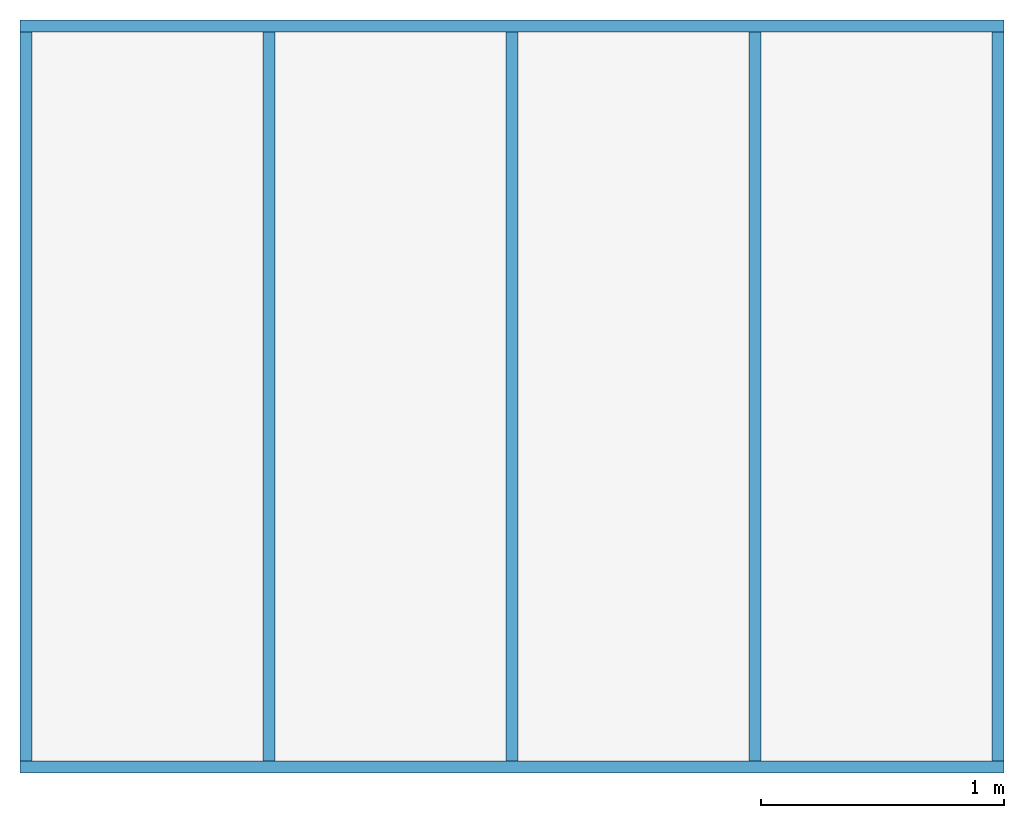
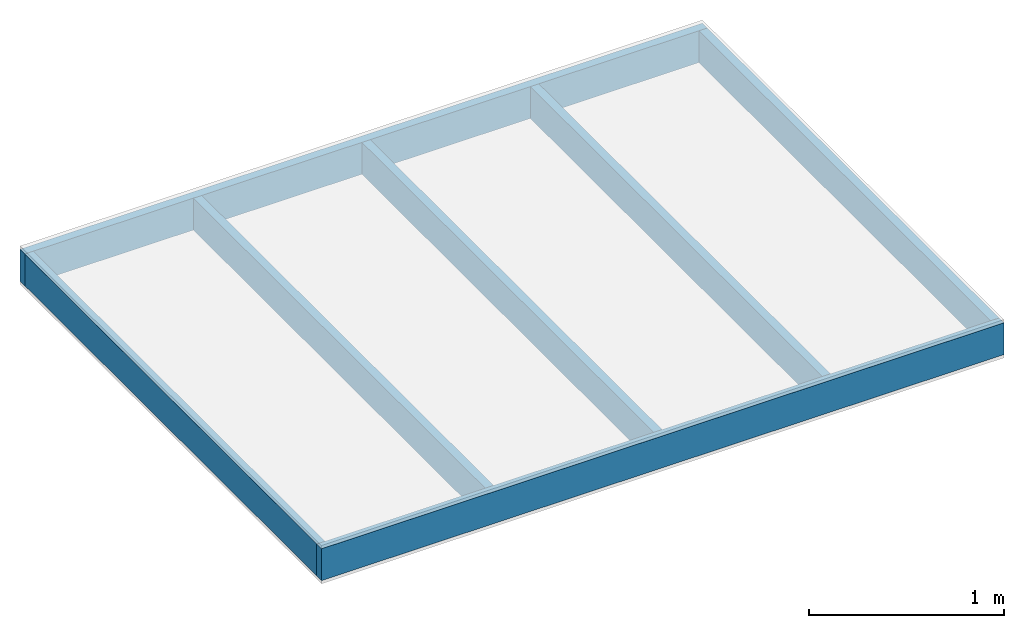
# One storey, part 1 of 2: 6 members, 1 beam.
"""IFC4 building model written with IfcOpenShell, lengths in millimetres."""

from ifc_helpers import new_model, si_unit, frame, origin_with_axes, origin_2d_with_axis, place, context, subcontext, project, spatial, rectangle, extrude, element, save


model = new_model("IFC4")

# Units and contexts
model_context_1 = context("Model", 3, precision=1e-05, world=origin_with_axes())
model_context_2 = context("Model", 3, precision=1e-05, world=origin_with_axes())
plan_context = context("Plan", 2, precision=1e-05, world=origin_2d_with_axis())
body_context = subcontext(model_context_2, "Body", "Model", "MODEL_VIEW")
ifc_project = project(units=[si_unit("AREAUNIT", "SQUARE_METRE"), si_unit("VOLUMEUNIT", "CUBIC_METRE"), si_unit("LENGTHUNIT", "METRE", prefix="MILLI")], contexts=[model_context_1, model_context_2, plan_context])

# Site, building, storey
site = spatial("IfcSite", under=ifc_project)
building = spatial("IfcBuilding", under=site, Name="Building A")
storey = spatial("IfcBuildingStorey", under=building, Name="Ground Floor")

# Members
for number, where, z_axis, x_axis, name in (
    (1, (0.0, 25.0, 0.0), (0.0, 1.0, 0.0), (1.0, 1.0, 0.0), "my_beam"),
    (2, (1000.0, 25.0, 0.0), (0.0, 1.0, 0.0), (1.0, 1.0, 0.0), "my_beam"),
    (3, (2000.0, 25.0, 0.0), (0.0, 1.0, 0.0), (1.0, 1.0, 0.0), "my_beam"),
    (4, (3000.0, 25.0, 0.0), (0.0, 1.0, 0.0), (1.0, 1.0, 0.0), "my_beam"),
    (5, (4000.0, 25.0, 0.0), (0.0, 1.0, 0.0), (1.0, 1.0, 0.0), "my_beam"),
):
    element("IfcMember", number, at=place(None, frame(where, z_axis=z_axis, x_axis=x_axis)), inside=storey, Name=name, context=body_context, shape_type="SweptSolid", body=[
        extrude(rectangle(XDim=50.0, YDim=200.0), origin_with_axes(), (0.0, 0.0, 1.0), 3000.0),
    ])
member_placement = place(None, frame((-25.0, 0.0, 0.0), z_axis=(1.0, 0.0, 0.0), x_axis=(1.0, 1.0, 0.0)))
element("IfcMember", 6, at=member_placement, inside=storey, Name="my_beam", context=body_context, shape_type="SweptSolid", body=[
    extrude(rectangle(XDim=50.0, YDim=200.0), origin_with_axes(), (0.0, 0.0, 1.0), 4050.0),
])

# Beam
beam_placement = place(None, frame((-25.0, 3050.0, 0.0), z_axis=(1.0, 0.0, 0.0), x_axis=(1.0, 1.0, 0.0)))
element("IfcBeam", 7, at=beam_placement, inside=storey, Name="my_beam", context=body_context, shape_type="SweptSolid", body=[
    extrude(rectangle(XDim=50.0, YDim=200.0), origin_with_axes(), (0.0, 0.0, 1.0), 4050.0),
])

save(model, "model.ifc")
